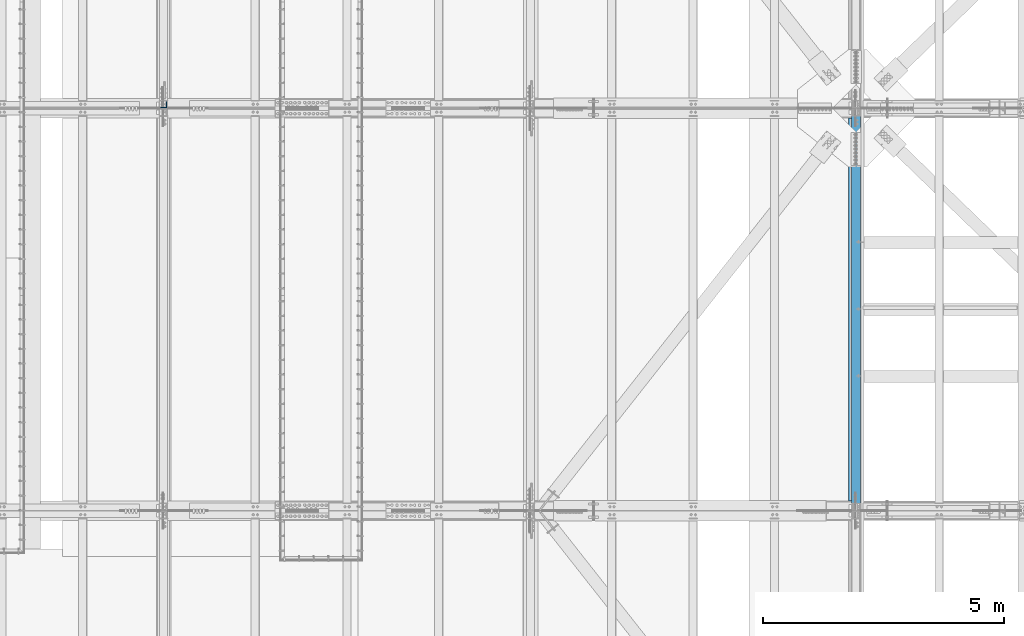
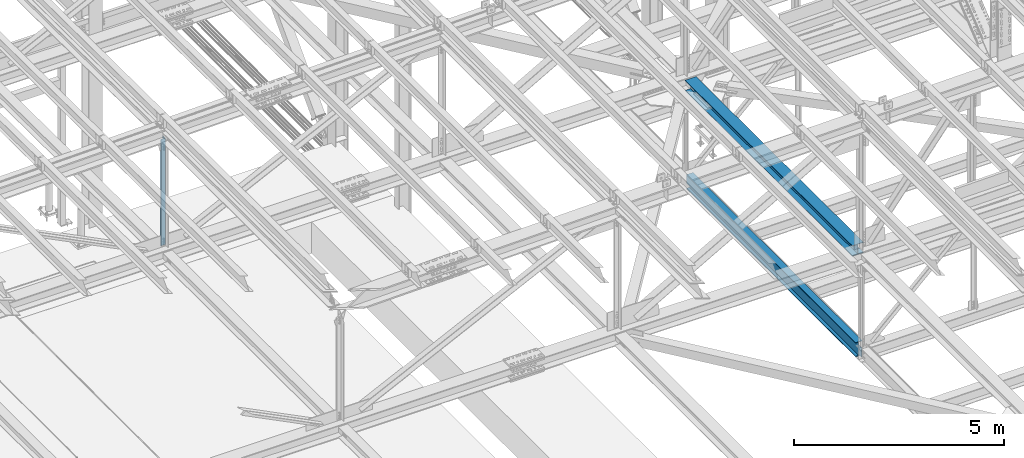
# One storey, part 1903 of 3843: 3 beams, 3 elements without a shape of their own.
"""IFC2X3 building model written with IfcOpenShell, lengths in millimetres."""

from ifc_helpers import new_model, si_unit, frame, origin_with_axes, place, context, subcontext, project, spatial, faceted_brep, material, type_object, element, aggregate, save


model = new_model("IFC2X3")

# Units and contexts
model_context = context("Model", 3, precision=1e-05, world=origin_with_axes())
body_context = subcontext(model_context, "Body", "Model", "MODEL_VIEW")
ifc_project = project(units=[si_unit("LENGTHUNIT", "METRE", prefix="MILLI"), si_unit("AREAUNIT", "SQUARE_METRE"), si_unit("VOLUMEUNIT", "CUBIC_METRE"), si_unit("MASSUNIT", "GRAM", prefix="KILO"), si_unit("TIMEUNIT", "SECOND"), si_unit("PLANEANGLEUNIT", "RADIAN"), si_unit("SOLIDANGLEUNIT", "STERADIAN"), si_unit("THERMODYNAMICTEMPERATUREUNIT", "DEGREE_CELSIUS"), si_unit("LUMINOUSINTENSITYUNIT", "LUMEN")], contexts=[model_context])

# Site, building, storey
site_placement = place(None, origin_with_axes())
site = spatial("IfcSite", under=ifc_project, at=site_placement, CompositionType="ELEMENT")
building_placement = place(site_placement, origin_with_axes())
building = spatial("IfcBuilding", under=site, at=building_placement, Name="Undefined", CompositionType="ELEMENT")
storey_placement = place(building_placement, origin_with_axes())
storey = spatial("IfcBuildingStorey", under=building, at=storey_placement, Name="Undefined", CompositionType="ELEMENT", Elevation=0.0)

# Assembly, beam
assembly_1_placement = place(storey_placement, origin_with_axes())
assembly_1 = element("IfcElementAssembly", 1, at=assembly_1_placement, inside=storey, Name="ANGLE", AssemblyPlace="NOTDEFINED", PredefinedType="RIGID_FRAME")
ifc_material_1 = material(Name="STEEL/A572-50")
beam_type_1 = type_object("IfcBeamType", Name="L5X5X3/8", PredefinedType="NOTDEFINED")
beam_1_placement = place(assembly_1_placement, frame((62636.4, 75701.525, 45851.6758371081), z_axis=(-1.0, 0.0, 0.0), x_axis=(0.0, 0.0, -1.0)))
beam_1 = element("IfcBeam", 2, at=beam_1_placement, type_object=beam_type_1, material=ifc_material_1, Name="ANGLE", ObjectType="L5X5X3/8", context=body_context, shape_type="Brep", body=[
    faceted_brep([(224.489315816558, 63.5, -63.5), (224.489315816558, 63.5, 63.5), (3317.13247189415, 63.5, 63.5), (3317.13247189415, 63.5, -63.5), (224.489315816558, 53.9750000000058, 63.5), (3317.13247189415, 53.9750000000058, 63.5), (224.489315816558, 53.9750000000058, -53.9749999999985), (3317.13247189415, 53.9750000000058, -53.9749999999985), (224.489315816558, -63.5, -53.9749999999985), (3317.13247189415, -63.5, -53.9749999999985), (224.489315816558, -63.5, -63.5), (3317.13247189415, -63.5, -63.5)], [[[0, 1, 2, 3]], [[1, 4, 5, 2]], [[4, 6, 7, 5]], [[6, 8, 9, 7]], [[8, 10, 11, 9]], [[10, 0, 3, 11]], [[5, 7, 9, 11, 3, 2]], [[10, 8, 6, 4, 1, 0]]]),
])
aggregate(assembly_1, [beam_1])

assembly_2_placement = place(storey_placement, origin_with_axes())
assembly_2 = element("IfcElementAssembly", 3, at=assembly_2_placement, inside=storey, Name="BEAM", AssemblyPlace="NOTDEFINED", PredefinedType="RIGID_FRAME")
ifc_material_2 = material(Name="STEEL/A992")
beam_type_2 = type_object("IfcBeamType", Name="W12X65", PredefinedType="NOTDEFINED")
beam_2_placement = place(assembly_2_placement, frame((77012.8, 67271.9000000011, 42337.744959466), z_axis=(0.0, 0.00216623899934348, 0.999997653701546), x_axis=(0.0, 0.999997653701546, -0.00216623899934971)))
beam_2 = element("IfcBeam", 4, at=beam_2_placement, type_object=beam_type_2, material=ifc_material_2, Name="BEAM", ObjectType="W12X65", context=body_context, shape_type="Brep", body=[
    faceted_brep([(198.771537093911, 152.399999999994, -153.987499999719), (198.737147969208, 152.399999999994, -138.112499999741), (8158.48082700818, 152.399999999994, -138.112499997238), (8158.51521613287, 152.399999999994, -153.987499997216), (198.737147969208, 4.76249999999709, -138.112499999741), (8158.48082700818, 4.76249999999709, -138.112499997238), (198.138777199667, 4.76249999999709, 138.112499999872), (8157.88245623864, 4.76249999999709, 138.112500002368), (198.138777199667, 152.399999999994, 138.112499999872), (8157.88245623864, 152.399999999994, 138.112500002368), (198.104388074978, 152.399999999994, 153.98749999985), (8157.84806711396, 152.399999999994, 153.987500002346), (198.104388074978, -152.399999999994, 153.98749999985), (8157.84806711396, -152.399999999994, 153.987500002346), (198.138777199667, -152.399999999994, 138.112499999872), (8157.88245623864, -152.399999999994, 138.112500002368), (198.138777199667, -4.76249999999709, 138.112499999872), (8157.88245623864, -4.76249999999709, 138.112500002368), (198.737147969208, -4.76249999999709, -138.112499999741), (8158.48082700818, -4.76249999999709, -138.112499997238), (198.737147969208, -152.399999999994, -138.112499999741), (8158.48082700818, -152.399999999994, -138.112499997238), (198.771537093911, -152.399999999994, -153.987499999719), (8158.51521613287, -152.399999999994, -153.987499997216)], [[[0, 1, 2, 3]], [[1, 4, 5, 2]], [[4, 6, 7, 5]], [[6, 8, 9, 7]], [[8, 10, 11, 9]], [[10, 12, 13, 11]], [[12, 14, 15, 13]], [[14, 16, 17, 15]], [[16, 18, 19, 17]], [[18, 20, 21, 19]], [[20, 22, 23, 21]], [[22, 0, 3, 23]], [[5, 7, 9, 11, 13, 15, 17, 19, 21, 23, 3, 2]], [[22, 20, 18, 16, 14, 12, 10, 8, 6, 4, 1, 0]]]),
])
aggregate(assembly_2, [beam_2])

assembly_3_placement = place(storey_placement, origin_with_axes())
assembly_3 = element("IfcElementAssembly", 5, at=assembly_3_placement, inside=storey, Name="BEAM", AssemblyPlace="NOTDEFINED", PredefinedType="RIGID_FRAME")
beam_type_3 = type_object("IfcBeamType", Name="W16X57", PredefinedType="NOTDEFINED")
beam_3_placement = place(assembly_3_placement, frame((77012.8, 67271.9, 39476.3625), z_axis=(0.0, 0.0, 1.0), x_axis=(0.0, 1.0, 0.0)))
beam_3 = element("IfcBeam", 6, at=beam_3_placement, type_object=beam_type_3, material=ifc_material_2, Name="BEAM", ObjectType="W16X57", context=body_context, shape_type="Brep", body=[
    faceted_brep([(8204.99375000002, -5.55624999999418, -190.5), (8204.99375000002, -90.4875000000029, -190.5), (8204.99375000002, -90.4875000000029, -207.962500000001), (8204.99375000002, 90.4875000000029, -207.962500000001), (8204.99375000002, 90.4875000000029, -190.5), (8204.99375000002, 5.55624999999418, -190.5), (8204.99375000002, 5.55624999999418, -170.122499798672), (8204.99375000002, -5.55624999999418, -170.122499798672), (8205.96047992261, 5.55624999999418, -165.262420280626), (8205.96047992261, -5.55624999999418, -165.262420280626), (8208.71349382309, 5.55624999999418, -161.142243812472), (8208.71349382309, -5.55624999999418, -161.142243812472), (8212.83367029125, 5.55624999999418, -158.389229911998), (8212.83367029125, -5.55624999999418, -158.389229911998), (8217.69374980929, 5.55624999999418, -157.422499989407), (8217.69374980929, -5.55624999999418, -157.422499989407), (8338.34375000003, -5.55624999999418, -157.422499989407), (8338.34375000003, 5.55624999999418, -157.422499989407), (151.606250000026, 5.55624999999418, 190.5), (151.606250000026, 90.4875000000029, 190.5), (8204.99375000002, 90.4875000000029, 190.5), (8204.99375000002, 5.55624999999418, 190.5), (151.606250000026, -5.55624999999418, -170.122499798665), (151.606250000026, 5.55624999999418, -170.122499798665), (151.606250000026, 5.55624999999418, -190.5), (151.606250000026, 90.4875000000029, -190.5), (151.606250000026, 90.4875000000029, -207.962500000001), (151.606250000026, -90.4875000000029, -207.962500000001), (151.606250000026, -90.4875000000029, -190.5), (151.606250000026, -5.55624999999418, -190.5), (150.639520077442, -5.55624999999418, -165.262420280618), (150.639520077442, 5.55624999999418, -165.262420280618), (147.886506176961, -5.55624999999418, -161.142243812465), (147.886506176961, 5.55624999999418, -161.142243812465), (143.7663297088, -5.55624999999418, -158.389229911991), (143.7663297088, 5.55624999999418, -158.389229911991), (138.906250190761, -5.55624999999418, -157.4224999894), (138.906250190761, 5.55624999999418, -157.4224999894), (18.2562499999913, -5.55624999999418, -157.4224999894), (18.2562499999913, 5.55624999999418, -157.4224999894), (18.2562499999913, -5.55624999999418, 106.102500010602), (18.2562499999913, 5.55624999999418, 106.102500010602), (138.906250190761, -5.55624999999418, 106.102500010602), (138.906250190761, 5.55624999999418, 106.102500010602), (143.7663297088, -5.55624999999418, 107.069229933193), (143.7663297088, 5.55624999999418, 107.069229933193), (147.886506176961, -5.55624999999418, 109.822243833667), (147.886506176961, 5.55624999999418, 109.822243833667), (150.639520077442, -5.55624999999418, 113.942420301821), (150.639520077442, 5.55624999999418, 113.942420301821), (151.606250000026, -5.55624999999418, 118.802499819867), (151.606250000026, 5.55624999999418, 118.802499819867), (151.606250000026, -90.4875000000029, 207.962500000001), (151.606250000026, 90.4875000000029, 207.962500000001), (151.606250000026, -5.55624999999418, 190.5), (151.606250000026, -90.4875000000029, 190.5), (8204.99375000002, -5.55624999999418, 190.5), (8204.99375000002, -90.4875000000029, 190.5), (8204.99375000002, -90.4875000000029, 207.962500000001), (8204.99375000002, 90.4875000000029, 207.962500000001), (8204.99375000002, -5.55624999999418, 118.80249981986), (8204.99375000002, 5.55624999999418, 118.80249981986), (8205.96047992261, -5.55624999999418, 113.942420301813), (8205.96047992261, 5.55624999999418, 113.942420301813), (8208.71349382309, -5.55624999999418, 109.82224383366), (8208.71349382309, 5.55624999999418, 109.82224383366), (8212.83367029125, -5.55624999999418, 107.069229933186), (8212.83367029125, 5.55624999999418, 107.069229933186), (8217.69374980929, -5.55624999999418, 106.102500010595), (8217.69374980929, 5.55624999999418, 106.102500010595), (8338.34375000003, -5.55624999999418, 106.102500010595), (8338.34375000003, 5.55624999999418, 106.102500010595)], [[[0, 1, 2, 3, 4, 5, 6, 7]], [[7, 6, 8, 9]], [[9, 8, 10, 11]], [[11, 10, 12, 13]], [[13, 12, 14, 15]], [[16, 15, 14, 17]], [[18, 19, 20, 21]], [[22, 23, 24, 25, 26, 27, 28, 29]], [[30, 31, 23, 22]], [[32, 33, 31, 30]], [[34, 35, 33, 32]], [[36, 37, 35, 34]], [[38, 39, 37, 36]], [[40, 41, 39, 38]], [[42, 43, 41, 40]], [[44, 45, 43, 42]], [[46, 47, 45, 44]], [[48, 49, 47, 46]], [[50, 51, 49, 48]], [[52, 53, 19, 18, 51, 50, 54, 55]], [[55, 54, 56, 57]], [[52, 55, 57, 58]], [[53, 52, 58, 59]], [[19, 53, 59, 20]], [[58, 57, 56, 60, 61, 21, 20, 59]], [[62, 63, 61, 60]], [[64, 65, 63, 62]], [[66, 67, 65, 64]], [[68, 69, 67, 66]], [[70, 71, 69, 68]], [[71, 70, 16, 17]], [[12, 10, 8, 6, 5, 24, 23, 31, 33, 35, 37, 39, 41, 43, 45, 47, 49, 51, 18, 21, 61, 63, 65, 67, 69, 71, 17, 14]], [[25, 24, 5, 4]], [[26, 25, 4, 3]], [[27, 26, 3, 2]], [[28, 27, 2, 1]], [[29, 28, 1, 0]], [[70, 68, 66, 64, 62, 60, 56, 54, 50, 48, 46, 44, 42, 40, 38, 36, 34, 32, 30, 22, 29, 0, 7, 9, 11, 13, 15, 16]]]),
])
aggregate(assembly_3, [beam_3])

save(model, "model.ifc")
